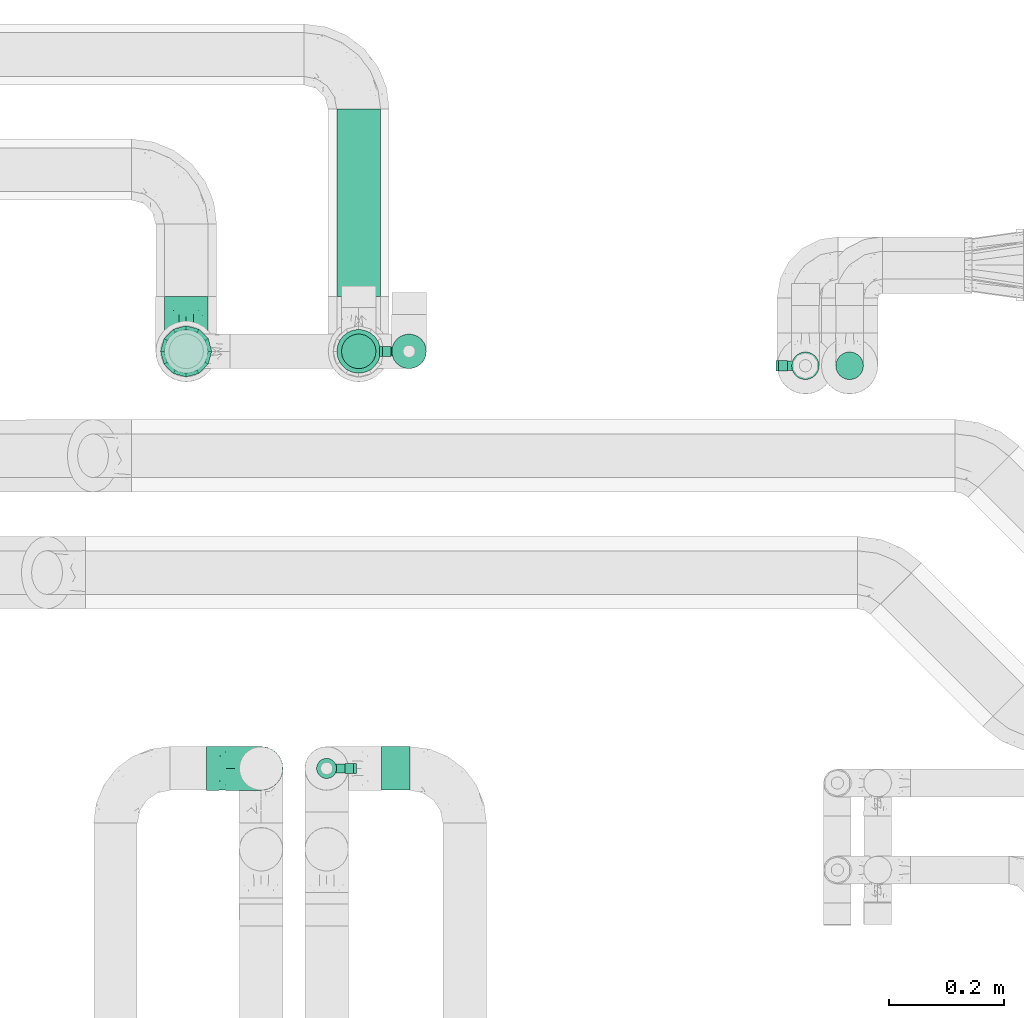
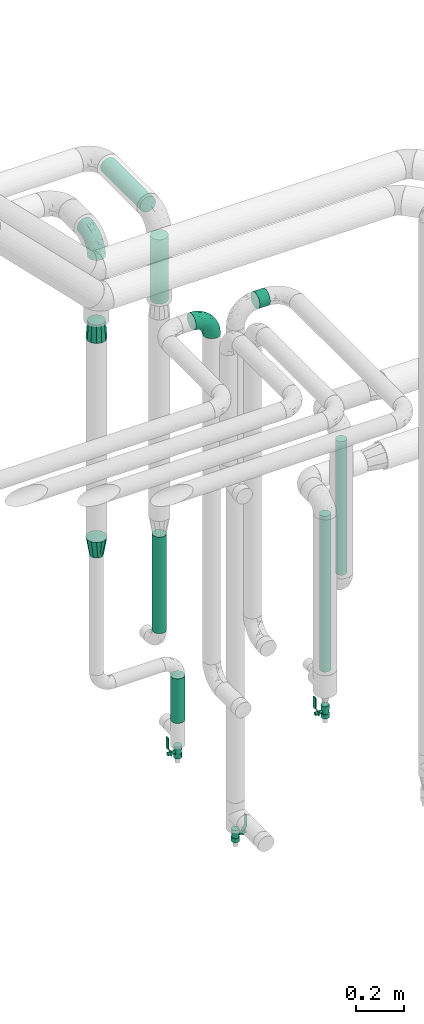
# One storey, part 682 of 827: 7 flow segments, 4 flow fittings, 3 flow controllers.
"""IFC2X3 building model written with IfcOpenShell, lengths in millimetres."""

import ifcopenshell
import ifcopenshell.guid

model = None  # the IFC model being written
_history = None  # IfcOwnerHistory: only IFC2X3 demands one
_inside = {}  # id of a spatial element -> (the spatial element, [elements in it])
_under = {}  # id of a project, library or spatial element -> (it, [spatial elements below it])
_declared = {}  # id of a project -> (the project, [libraries it declares])
_typed = {}  # id of a type object -> (the type object, [elements of that type])
_made_of = {}  # id of a material, layer set ... -> (it, [elements and type objects made of it])


def new_model(schema):
    """Start an empty IFC model of exactly this schema.

    Asked for "IFC4X3", IfcOpenShell would pick the latest addendum, in which some entities
    have other attributes; the version numbers below select the first issue.
    IFC2X3 requires an IfcOwnerHistory on every rooted entity: one is made here for all.
    """
    global model, _history
    if schema == "IFC4X3":
        model = ifcopenshell.file(schema_version=(4, 3, 0, 0))
    else:
        model = ifcopenshell.file(schema=schema)
    _inside.clear()
    _under.clear()
    _declared.clear()
    _typed.clear()
    _made_of.clear()
    _history = None
    if model.schema == "IFC2X3":
        org = make("IfcOrganization", Name="unknown")
        user = make(
            "IfcPersonAndOrganization",
            ThePerson=make("IfcPerson", FamilyName="unknown"),
            TheOrganization=org,
        )
        app = make(
            "IfcApplication",
            ApplicationDeveloper=org,
            Version="unknown",
            ApplicationFullName="unknown",
            ApplicationIdentifier="unknown",
        )
        _history = make(
            "IfcOwnerHistory",
            OwningUser=user,
            OwningApplication=app,
            ChangeAction="ADDED",
            CreationDate=0,
        )
    return model


def make(cls, **values):
    """One entity of the class cls with the attributes given. An attribute that is None is left unset."""
    return model.create_entity(
        cls, **{name: value for name, value in values.items() if value is not None}
    )


def entity(cls, *values):
    """Any entity or typed value of the class cls, its attributes in the order of the schema. None: left unset."""
    e = model.create_entity(cls)
    for i, value in enumerate(values):
        if value is not None:
            e[i] = value
    return e


def rooted(cls, **values):
    """An entity with a GlobalId (a new one), such as an element, a storey or a relation."""
    return make(cls, GlobalId=ifcopenshell.guid.new(), OwnerHistory=_history, **values)


def si_unit(unit_type, name, prefix=None):
    """IfcSIUnit, for example si_unit("LENGTHUNIT", "METRE", prefix="MILLI")."""
    return make("IfcSIUnit", UnitType=unit_type, Prefix=prefix, Name=name)


def converted_unit(unit_type, name, factor, base, dimensions=None, offset=None):
    """IfcConversionBasedUnit, such as the inch: factor (a typed value) times the base unit."""
    return make(
        "IfcConversionBasedUnit"
        if offset is None
        else "IfcConversionBasedUnitWithOffset",
        ConversionOffset=offset,
        Dimensions=None
        if dimensions is None
        else entity("IfcDimensionalExponents", *dimensions),
        UnitType=unit_type,
        Name=name,
        ConversionFactor=make(
            "IfcMeasureWithUnit", ValueComponent=factor, UnitComponent=base
        ),
    )


def derived_unit(unit_type, elements):
    """IfcDerivedUnit: a product of units, each with its exponent."""
    return make(
        "IfcDerivedUnit",
        Elements=[
            make("IfcDerivedUnitElement", Unit=unit, Exponent=power)
            for unit, power in elements
        ],
        UnitType=unit_type,
    )


def assignment(units):
    """IfcUnitAssignment: the units of a project."""
    return None if units is None else make("IfcUnitAssignment", Units=units)


def point(xyz):
    """IfcCartesianPoint."""
    return None if xyz is None else make("IfcCartesianPoint", Coordinates=xyz)


def direction(xyz):
    """IfcDirection."""
    return None if xyz is None else make("IfcDirection", DirectionRatios=xyz)


def frame(location, z_axis=None, x_axis=None):
    """IfcAxis2Placement3D, a coordinate frame: its origin and axes. An axis left out is left unset."""
    return make(
        "IfcAxis2Placement3D",
        Location=point(location),
        Axis=direction(z_axis),
        RefDirection=direction(x_axis),
    )


def frame_2d(location, x_axis=None):
    """IfcAxis2Placement2D, a coordinate frame in the plane: its origin and x axis."""
    return make(
        "IfcAxis2Placement2D", Location=point(location), RefDirection=direction(x_axis)
    )


def origin():
    """The frame at (0, 0, 0) with its axes left unset."""
    return frame((0.0, 0.0, 0.0))


def origin_2d_with_axis():
    """The frame at (0, 0) in the plane with the x axis (1, 0) written out."""
    return frame_2d((0.0, 0.0), x_axis=(1.0, 0.0))


def place(relative_to, where):
    """IfcLocalPlacement: puts the frame where relative to a parent placement (None: the world)."""
    return make(
        "IfcLocalPlacement", PlacementRelTo=relative_to, RelativePlacement=where
    )


def context(
    kind, dimensions, precision=None, world=None, true_north=None, identifier=None
):
    """IfcGeometricRepresentationContext, for example the 3D "Model" context."""
    return make(
        "IfcGeometricRepresentationContext",
        ContextIdentifier=identifier,
        ContextType=kind,
        CoordinateSpaceDimension=dimensions,
        Precision=precision,
        WorldCoordinateSystem=world,
        TrueNorth=true_north,
    )


def subcontext(parent, identifier, kind, view, scale=None):
    """IfcGeometricRepresentationSubContext, for example "Body" below "Model"."""
    return make(
        "IfcGeometricRepresentationSubContext",
        ContextIdentifier=identifier,
        ContextType=kind,
        ParentContext=parent,
        TargetScale=scale,
        TargetView=view,
    )


def project(units=None, contexts=None):
    """IfcProject with its units and contexts."""
    return rooted(
        "IfcProject",
        Name="project",
        RepresentationContexts=contexts,
        UnitsInContext=assignment(units),
    )


def spatial(cls, under=None, at=None, **own):
    """A site, building, storey or space (cls), placed at a placement, below another one or the project."""
    s = rooted(cls, ObjectPlacement=at, **own)
    if under is not None:
        _under.setdefault(under.id(), (under, []))[1].append(s)
    return s


def polyline(points):
    """IfcPolyline through the points."""
    return make("IfcPolyline", Points=[point(p) for p in points])


def profile(cls, at=None, kind="AREA", **sizes):
    """A parametric profile (cls). Its sizes go by their IFC names, for example OverallWidth=200.0."""
    return make(cls, ProfileType=kind, Position=at, **sizes)


def circle(**sizes):
    """IfcCircleProfileDef."""
    return profile("IfcCircleProfileDef", **sizes)


def outline(outer, holes=None, kind="AREA"):
    """IfcArbitraryClosedProfileDef: a profile drawn as a closed curve; with holes, ...WithVoids."""
    if holes is None:
        return make("IfcArbitraryClosedProfileDef", ProfileType=kind, OuterCurve=outer)
    return make(
        "IfcArbitraryProfileDefWithVoids",
        ProfileType=kind,
        OuterCurve=outer,
        InnerCurves=holes,
    )


def extrude(swept, where, along, depth):
    """IfcExtrudedAreaSolid: the profile swept, set in the frame where, extruded along a direction by depth."""
    return make(
        "IfcExtrudedAreaSolid",
        SweptArea=swept,
        Position=where,
        ExtrudedDirection=direction(along),
        Depth=depth,
    )


def faces_of(points, faces, orient=None, outer=None):
    """IfcFace entities. A face is a list of loops; a loop is a list of indices into points, from 0.

    orient and outer hold one flag for each loop. By default every Orientation is true, the
    first loop of a face is its IfcFaceOuterBound and the others are IfcFaceBound.
    """
    made = []
    for i, loops in enumerate(faces):
        bounds = []
        for j, loop in enumerate(loops):
            is_outer = j == 0 if outer is None else outer[i][j]
            bounds.append(
                make(
                    "IfcFaceOuterBound" if is_outer else "IfcFaceBound",
                    Bound=make("IfcPolyLoop", Polygon=[points[k] for k in loop]),
                    Orientation=True if orient is None else orient[i][j],
                )
            )
        made.append(make("IfcFace", Bounds=bounds))
    return made


def faceted_brep(points, faces, orient=None, outer=None, voids=None):
    """IfcFacetedBrep: a solid bounded by flat faces; with voids (closed shells), ...WithVoids."""
    shared = [point(p) for p in points]
    hull = make("IfcClosedShell", CfsFaces=faces_of(shared, faces, orient, outer))
    if voids is None:
        return make("IfcFacetedBrep", Outer=hull)
    return make(
        "IfcFacetedBrepWithVoids",
        Outer=hull,
        Voids=[
            make(cls, CfsFaces=faces_of(shared, fs, o, b)) for cls, fs, o, b in voids
        ],
    )


def shape(context_of_items, identifier, shape_type, items):
    """IfcShapeRepresentation: the items that make up one representation, for example the "Body"."""
    return make(
        "IfcShapeRepresentation",
        ContextOfItems=context_of_items,
        RepresentationIdentifier=identifier,
        RepresentationType=shape_type,
        Items=items,
    )


def source(mapping_origin, context_of_items, identifier, shape_type, items):
    """IfcRepresentationMap: a shape defined once, which mapped items show again and again."""
    return make(
        "IfcRepresentationMap",
        MappingOrigin=mapping_origin,
        MappedRepresentation=shape(context_of_items, identifier, shape_type, items),
    )


def transform(
    local_origin,
    x_axis=None,
    y_axis=None,
    z_axis=None,
    scale=None,
    scale2=None,
    scale3=None,
    uniform=True,
):
    """IfcCartesianTransformationOperator3D, or its non-uniform kind. x_axis, y_axis, z_axis: its Axis1, 2, 3."""
    if uniform:
        return make(
            "IfcCartesianTransformationOperator3D",
            Axis1=direction(x_axis),
            Axis2=direction(y_axis),
            LocalOrigin=point(local_origin),
            Scale=scale,
            Axis3=direction(z_axis),
        )
    return make(
        "IfcCartesianTransformationOperator3DnonUniform",
        Axis1=direction(x_axis),
        Axis2=direction(y_axis),
        LocalOrigin=point(local_origin),
        Scale=scale,
        Axis3=direction(z_axis),
        Scale2=scale2,
        Scale3=scale3,
    )


def mapped(mapping_source, mapping_target):
    """IfcMappedItem: shows the shape of a source again, moved by a transform."""
    return make(
        "IfcMappedItem", MappingSource=mapping_source, MappingTarget=mapping_target
    )


def material(Name=None, Category=None):
    """IfcMaterial."""
    return make("IfcMaterial", Name=Name, Category=Category)


def material_list(materials):
    """IfcMaterialList."""
    return make("IfcMaterialList", Materials=materials)


def made_of(thing, what):
    """Note that an element or type object is made of a material, layer set ...; save() writes the relation."""
    if what is not None:
        _made_of.setdefault(what.id(), (what, []))[1].append(thing)
    return thing


def type_object(cls, material=None, **own):
    """A type object (cls), such as IfcWallType, which elements share."""
    return made_of(rooted(cls, **own), material)


def type_shapes(of_type, sources):
    """Give a type object the sources (RepresentationMaps) that its elements show as mapped items."""
    of_type.RepresentationMaps = sources


def element(
    cls,
    number,
    at=None,
    inside=None,
    cuts=None,
    type_object=None,
    material=None,
    context=None,
    identifier="Body",
    shape_type=None,
    held_by="IfcProductDefinitionShape",
    body=None,
    shapes=None,
    **own,
):
    """One element of the class cls, such as IfcWall. Its Tag is "e" and its number.

    at: its placement. inside: the storey or other place that contains it. cuts: it is an
    opening in that element (IfcRelVoidsElement). A single representation is given by context,
    identifier, shape_type and body (its items); several are given by shapes. held_by: the class
    of the entity that holds the representations. save() writes the other relations.
    """
    e = rooted(cls, Tag="e%d" % number, ObjectPlacement=at, **own)
    if body is not None:
        shapes = [shape(context, identifier, shape_type, body)]
    if shapes is not None:
        e.Representation = make(held_by, Representations=shapes)
    if inside is not None:
        _inside.setdefault(inside.id(), (inside, []))[1].append(e)
    if cuts is not None:
        rooted(
            "IfcRelVoidsElement", RelatingBuildingElement=cuts, RelatedOpeningElement=e
        )
    if type_object is not None:
        _typed.setdefault(type_object.id(), (type_object, []))[1].append(e)
    return made_of(e, material)


def aggregate(whole, parts):
    """IfcRelAggregates: a whole, such as a stair, and the parts it consists of."""
    return rooted("IfcRelAggregates", RelatingObject=whole, RelatedObjects=parts)


def save(model, path):
    """Write the relations noted so far, then the file.

    IfcRelAggregates (storeys below a building ...), IfcRelContainedInSpatialStructure (elements
    in a storey), IfcRelDefinesByType, IfcRelAssociatesMaterial and IfcRelDeclares: one each for
    every whole, place, type object, material and project.
    """
    for whole, parts in _under.values():
        aggregate(whole, parts)
    for where, things in _inside.values():
        rooted(
            "IfcRelContainedInSpatialStructure",
            RelatedElements=things,
            RelatingStructure=where,
        )
    for kind, things in _typed.values():
        rooted("IfcRelDefinesByType", RelatedObjects=things, RelatingType=kind)
    for what, things in _made_of.values():
        rooted("IfcRelAssociatesMaterial", RelatedObjects=things, RelatingMaterial=what)
    for by, libraries in _declared.values():
        rooted("IfcRelDeclares", RelatingContext=by, RelatedDefinitions=libraries)
    model.write(path)


model = new_model("IFC2X3")

# Units and contexts
model_context = context("Model", 3, precision=0.01, world=origin(), true_north=direction((6.12303176911189e-17, 1.0)))
body_context = subcontext(model_context, "Body", "Model", "MODEL_VIEW")
ifc_project = project(units=[si_unit("LENGTHUNIT", "METRE", prefix="MILLI"), si_unit("AREAUNIT", "SQUARE_METRE"), si_unit("VOLUMEUNIT", "CUBIC_METRE"), converted_unit("PLANEANGLEUNIT", "DEGREE", entity("IfcRatioMeasure", 0.0174532925199433), si_unit("PLANEANGLEUNIT", "RADIAN"), dimensions=[0, 0, 0, 0, 0, 0, 0]), si_unit("MASSUNIT", "GRAM", prefix="KILO"), derived_unit("MASSDENSITYUNIT", [(si_unit("MASSUNIT", "GRAM", prefix="KILO"), 1), (si_unit("LENGTHUNIT", "METRE"), -3)]), derived_unit("MOMENTOFINERTIAUNIT", [(si_unit("LENGTHUNIT", "METRE"), 4)]), si_unit("TIMEUNIT", "SECOND"), si_unit("FREQUENCYUNIT", "HERTZ"), si_unit("THERMODYNAMICTEMPERATUREUNIT", "DEGREE_CELSIUS"), derived_unit("THERMALTRANSMITTANCEUNIT", [(si_unit("MASSUNIT", "GRAM", prefix="KILO"), 1), (si_unit("THERMODYNAMICTEMPERATUREUNIT", "KELVIN"), -1), (si_unit("TIMEUNIT", "SECOND"), -3)]), derived_unit("VOLUMETRICFLOWRATEUNIT", [(si_unit("LENGTHUNIT", "METRE"), 3), (si_unit("TIMEUNIT", "SECOND"), -1)]), derived_unit("MASSFLOWRATEUNIT", [(si_unit("MASSUNIT", "GRAM", prefix="KILO"), 1), (si_unit("TIMEUNIT", "SECOND"), -1)]), derived_unit("ROTATIONALFREQUENCYUNIT", [(si_unit("TIMEUNIT", "SECOND"), -1)]), si_unit("ELECTRICCURRENTUNIT", "AMPERE"), si_unit("ELECTRICVOLTAGEUNIT", "VOLT"), si_unit("POWERUNIT", "WATT"), si_unit("FORCEUNIT", "NEWTON", prefix="KILO"), si_unit("ILLUMINANCEUNIT", "LUX"), si_unit("LUMINOUSFLUXUNIT", "LUMEN"), si_unit("LUMINOUSINTENSITYUNIT", "CANDELA"), derived_unit("USERDEFINED", [(si_unit("MASSUNIT", "GRAM", prefix="KILO"), -1), (si_unit("LENGTHUNIT", "METRE"), -2), (si_unit("TIMEUNIT", "SECOND"), 3), (si_unit("LUMINOUSFLUXUNIT", "LUMEN"), 1)]), derived_unit("LINEARVELOCITYUNIT", [(si_unit("LENGTHUNIT", "METRE"), 1), (si_unit("TIMEUNIT", "SECOND"), -1)]), si_unit("PRESSUREUNIT", "PASCAL"), derived_unit("USERDEFINED", [(si_unit("LENGTHUNIT", "METRE"), -2), (si_unit("MASSUNIT", "GRAM", prefix="KILO"), 1), (si_unit("TIMEUNIT", "SECOND"), -2)]), derived_unit("LINEARFORCEUNIT", [(si_unit("MASSUNIT", "GRAM", prefix="KILO"), 1), (si_unit("LENGTHUNIT", "METRE"), 1), (si_unit("TIMEUNIT", "SECOND"), -2), (si_unit("LENGTHUNIT", "METRE"), -1)]), derived_unit("PLANARFORCEUNIT", [(si_unit("MASSUNIT", "GRAM", prefix="KILO"), 1), (si_unit("LENGTHUNIT", "METRE"), 1), (si_unit("TIMEUNIT", "SECOND"), -2), (si_unit("LENGTHUNIT", "METRE"), -2)])], contexts=[model_context])

# Site, building, storey
site_placement = place(None, origin())
site = spatial("IfcSite", under=ifc_project, at=site_placement, CompositionType="ELEMENT")
building_placement = place(site_placement, origin())
building = spatial("IfcBuilding", under=site, at=building_placement, CompositionType="ELEMENT")
storey_placement = place(building_placement, frame((0.0, 0.0, 28200.0)))
storey = spatial("IfcBuildingStorey", under=building, at=storey_placement, Name="08", CompositionType="ELEMENT", Elevation=28200.0)

# Flow segments
pipe_segment_type_1 = type_object("IfcPipeSegmentType", PredefinedType="NOTDEFINED")
flow_segment_1_placement = place(storey_placement, frame((46768.22, 19086.22, 2960.4)))
element("IfcFlowSegment", 1, at=flow_segment_1_placement, inside=storey, type_object=pipe_segment_type_1, context=body_context, shape_type="SweptSolid", body=[
    extrude(circle(Radius=38.0, at=origin_2d_with_axis()), frame((39.6, 0.0, 39.6), z_axis=(0.0, 1.0, 0.0), x_axis=(-1.0, 0.0, 0.0)), (0.0, 0.0, 1.0), 326.0116),
])
flow_segment_2_placement = place(storey_placement, frame((46768.22, 18951.63, 2580.0)))
element("IfcFlowSegment", 2, at=flow_segment_2_placement, inside=storey, type_object=pipe_segment_type_1, context=body_context, shape_type="SweptSolid", body=[
    extrude(circle(Radius=38.0, at=origin_2d_with_axis()), frame((39.6, 39.6, 0.0)), (0.0, 0.0, 1.0), 325.000000000017),
])
pipe_segment_type_2 = type_object("IfcPipeSegmentType", PredefinedType="NOTDEFINED")
flow_segment_3_placement = place(storey_placement, frame((46847.07, 18226.89, 2960.65)))
element("IfcFlowSegment", 3, at=flow_segment_3_placement, inside=storey, type_object=pipe_segment_type_2, context=body_context, shape_type="SweptSolid", body=[
    extrude(circle(Radius=37.75, at=origin_2d_with_axis()), frame((0.0, 39.35, 39.35), z_axis=(1.0, 0.0, 0.0), x_axis=(0.0, 1.0, 0.0)), (0.0, 0.0, 1.0), 50.000000000006),
])
flow_segment_4_placement = place(storey_placement, frame((47558.7, 18940.63, 457.0)))
element("IfcFlowSegment", 4, at=flow_segment_4_placement, inside=storey, type_object=pipe_segment_type_2, context=body_context, shape_type="SweptSolid", body=[
    extrude(circle(Radius=24.0, at=origin_2d_with_axis()), frame((25.6, 25.6, 0.0)), (0.0, 0.0, 1.0), 785.999999709128),
])
flow_segment_5_placement = place(storey_placement, frame((47635.58, 18940.63, 918.88)))
element("IfcFlowSegment", 5, at=flow_segment_5_placement, inside=storey, type_object=pipe_segment_type_2, context=body_context, shape_type="SweptSolid", body=[
    extrude(circle(Radius=24.0, at=origin_2d_with_axis()), frame((25.6, 25.6, 0.0), z_axis=(0.0, 0.0, 1.0), x_axis=(-1.0, 0.0, 0.0)), (0.0, 0.0, 1.0), 674.12499999997),
])
flow_segment_6_placement = place(storey_placement, frame((46776.22, 18959.63, 912.38)))
element("IfcFlowSegment", 6, at=flow_segment_6_placement, inside=storey, type_object=pipe_segment_type_2, context=body_context, shape_type="SweptSolid", body=[
    extrude(circle(Radius=30.0, at=origin_2d_with_axis()), frame((31.6, 31.6, 0.0), z_axis=(0.0, 0.0, 1.0), x_axis=(-1.0, 0.0, 0.0)), (0.0, 0.0, 1.0), 486.500000000002),
])
flow_segment_7_placement = place(storey_placement, frame((46863.72, 18959.63, 429.0)))
element("IfcFlowSegment", 7, at=flow_segment_7_placement, inside=storey, type_object=pipe_segment_type_2, context=body_context, shape_type="SweptSolid", body=[
    extrude(circle(Radius=30.0, at=origin_2d_with_axis()), frame((31.6, 31.6, 0.0)), (0.0, 0.0, 1.0), 224.999999999888),
])

# Flow controllers
ifc_material = material()
ifc_material_list = material_list([ifc_material, ifc_material, ifc_material, ifc_material, ifc_material])
valve_type = type_object("IfcValveType", PredefinedType="NOTDEFINED", material=ifc_material_list)
shared_shape_1 = source(origin(), body_context, "Body", "SweptSolid", [
    extrude(circle(Radius=17.5, at=origin_2d_with_axis()), frame((-30.5, 0.0, 0.0), z_axis=(1.0, 0.0, 0.0), x_axis=(0.0, 1.0, 0.0)), (0.0, 0.0, 1.0), 20.3333333333333),
    extrude(circle(Radius=16.0, at=origin_2d_with_axis()), frame((-10.17, 0.0, 0.0), z_axis=(1.0, 0.0, 0.0), x_axis=(0.0, 1.0, 0.0)), (0.0, 0.0, 1.0), 20.3333333333333),
    extrude(circle(Radius=17.5, at=origin_2d_with_axis()), frame((10.17, 0.0, 0.0), z_axis=(1.0, 0.0, 0.0), x_axis=(0.0, 1.0, 0.0)), (0.0, 0.0, 1.0), 20.3333333333333),
    extrude(outline(polyline([(-38.75, -5.0), (-38.75, -10.0), (-17.92, -10.0), (2.08, 5.0), (56.25, 5.0), (56.25, 10.0), (0.42, 10.0), (-19.58, -5.0), (-38.75, -5.0)])), frame((28.75, -8.75, 41.5), z_axis=(0.0, -1.0, 0.0), x_axis=(1.0, 0.0, 0.0)), (0.0, 0.0, -1.0), 17.5),
    extrude(circle(Radius=8.0, at=origin_2d_with_axis()), origin(), (0.0, 0.0, 1.0), 49.0),
])
type_shapes(valve_type, [shared_shape_1])
for number, where, z_axis, x_axis in (
    (8, (47584.3, 18966.22, 247.5), (-1.0, 0.0, 0.0), (0.0, 0.0, 1.0)),
    (9, (46895.32, 18991.22, 270.5), (-1.0, 0.0, 0.0), (0.0, 0.0, 1.0)),
    (10, (46752.07, 18266.24, 338.5), (1.0, 0.0, 0.0), (0.0, 0.0, 1.0)),
):
    element("IfcFlowController", number, at=place(storey_placement, frame(where, z_axis=z_axis, x_axis=x_axis)), inside=storey, type_object=valve_type, material=ifc_material, context=body_context, shape_type="MappedRepresentation", body=[
        mapped(shared_shape_1, transform((0.0, 0.0, 0.0), scale=1.0)),
    ])

# Flow fittings
pipe_fitting_type_1 = type_object("IfcPipeFittingType", Name="ADSK_1", PredefinedType="NOTDEFINED", material=ifc_material)
shared_shape_2 = source(origin(), body_context, "Body", "Brep", [
    faceted_brep([(-95.0, 19.02, -32.95), (-95.0, 9.85, -36.75), (-95.0, 0.0, -38.05), (-95.0, -9.85, -36.75), (-95.0, -19.03, -32.95), (-95.0, -26.91, -26.91), (-95.0, -32.95, -19.03), (-95.0, -36.75, -9.85), (-95.0, -38.05, 0.0), (-95.0, -36.75, 9.85), (-95.0, -32.95, 19.02), (-95.0, -26.91, 26.91), (-95.0, -19.03, 32.95), (-95.0, -9.85, 36.75), (-95.0, 0.0, 38.05), (-95.0, 9.85, 36.75), (-95.0, 19.02, 32.95), (-95.0, 26.91, 26.91), (-95.0, 32.95, 19.02), (-95.0, 36.75, 9.85), (-95.0, 38.05, 0.0), (-95.0, 36.75, -9.85), (-95.0, 32.95, -19.03), (-95.0, 26.91, -26.91), (0.0, 95.0, -38.05), (-9.85, 95.0, -36.75), (-19.02, 95.0, -32.95), (-26.91, 95.0, -26.91), (-32.95, 95.0, -19.03), (-36.75, 95.0, -9.85), (-38.05, 95.0, 0.0), (-36.75, 95.0, 9.85), (-32.95, 95.0, 19.02), (-26.91, 95.0, 26.91), (-19.02, 95.0, 32.95), (-9.85, 95.0, 36.75), (0.0, 95.0, 38.05), (9.85, 95.0, 36.75), (19.03, 95.0, 32.95), (26.91, 95.0, 26.91), (32.95, 95.0, 19.02), (36.75, 95.0, 9.85), (38.05, 95.0, 0.0), (36.75, 95.0, -9.85), (32.95, 95.0, -19.03), (26.91, 95.0, -26.91), (19.03, 95.0, -32.95), (9.85, 95.0, -36.75), (-7.99, -4.96, 6.3), (-0.92, 0.92, 0.0), (4.62, 8.1, 8.01), (-76.19, -35.57, 0.0), (-64.32, -32.32, 12.43), (20.51, 62.45, 28.68), (-60.56, -33.52, 0.0), (-70.4, -13.47, 34.42), (-39.61, -5.88, 32.32), (-49.6, 2.07, 37.1), (-70.34, -28.81, 21.71), (14.64, 40.81, 26.5), (5.88, 39.61, 32.32), (3.59, 20.77, 25.31), (-40.45, 68.06, 16.75), (-62.45, -20.51, 28.68), (-44.52, -26.87, 0.0), (-28.47, -20.22, 0.0), (-26.43, -17.83, 8.75), (-76.1, 39.63, 10.76), (-72.74, 37.58, 18.19), (-60.35, 46.18, 14.61), (-13.4, 13.4, 32.12), (-20.77, -3.59, 25.31), (-14.66, 81.47, 35.56), (-6.22, 71.26, 37.92), (-57.5, 42.48, 22.79), (-15.0, 34.74, 37.7), (-27.1, 12.08, 36.05), (-9.2, 28.81, 35.63), (-79.98, 23.7, 30.95), (-73.68, -4.3, 37.48), (-30.74, 21.67, 37.97), (-62.36, 47.59, 6.79), (-72.71, 32.83, 24.69), (-67.42, 7.02, 37.95), (-32.13, 75.27, 24.51), (-43.46, 51.47, 26.26), (-24.98, 73.15, 31.29), (20.59, 41.28, 19.85), (7.79, 16.09, 15.86), (-73.21, 42.39, 0.0), (-54.73, 54.73, 0.0), (-73.44, 15.79, 35.79), (-5.94, 4.32, 20.43), (28.81, 70.34, 21.71), (32.32, 64.32, 12.43), (-53.59, 26.2, 35.09), (-52.02, 19.31, 37.21), (21.38, 33.53, 10.34), (26.87, 44.52, 0.0), (-48.28, 12.14, 38.05), (4.3, 73.68, 37.48), (-44.08, -25.52, 12.79), (-41.28, -20.59, 19.85), (35.57, 76.19, 0.0), (-47.26, 54.3, 20.18), (-47.4, 61.99, 8.58), (-42.39, 73.21, 0.0), (-39.67, 78.86, 7.21), (-45.69, 36.84, 33.11), (-32.83, 50.13, 33.35), (13.47, 70.4, 34.42), (-18.25, 63.73, 36.07), (-40.63, -13.75, 27.22), (-16.63, 46.37, 37.95), (-53.47, 38.79, 28.59), (-26.07, 48.54, 36.15), (-34.51, 34.51, 36.86), (-2.07, 49.6, 37.1), (-22.79, -10.49, 19.23), (-61.73, 28.67, 31.87), (9.65, 14.7, 0.0), (20.22, 28.47, 0.0), (33.52, 60.56, 0.0), (-11.42, -5.44, 13.25), (-14.7, -9.65, 0.0), (-81.47, 14.66, -35.56), (-62.45, -20.51, -28.68), (-71.26, 6.22, -37.92), (-75.27, 32.13, -24.51), (-73.15, 24.98, -31.29), (13.47, 70.4, -34.42), (5.88, 39.61, -32.32), (-2.07, 49.6, -37.1), (-78.86, 39.67, -7.21), (-70.4, -13.47, -34.42), (-39.61, -5.88, -32.32), (-61.99, 47.4, -8.58), (32.32, 64.32, -12.43), (28.81, 70.34, -21.71), (-63.73, 18.25, -36.07), (-50.13, 32.83, -33.35), (4.3, 73.68, -37.48), (-7.02, 67.42, -37.95), (-39.63, 76.1, -10.76), (-46.18, 60.35, -14.61), (-47.59, 62.36, -6.79), (-64.32, -32.32, -12.43), (-26.2, 53.59, -35.09), (-15.79, 73.44, -35.79), (-19.31, 52.02, -37.21), (-37.58, 72.74, -18.19), (-70.34, -28.81, -21.71), (-42.48, 57.5, -22.79), (-38.79, 53.47, -28.59), (-51.47, 43.46, -26.26), (-32.83, 72.71, -24.69), (-46.37, 16.63, -37.95), (-73.68, -4.3, -37.48), (-41.28, -20.59, -19.85), (-44.08, -25.52, -12.79), (13.75, 40.63, -27.22), (20.51, 62.45, -28.68), (-68.06, 40.45, -16.75), (-54.3, 47.26, -20.18), (-12.14, 48.28, -38.05), (-21.67, 30.74, -37.97), (-36.84, 45.69, -33.11), (-11.42, -5.44, -13.25), (7.79, 16.09, -15.86), (4.62, 8.1, -8.01), (-23.7, 79.98, -30.95), (-26.43, -17.83, -8.75), (-7.99, -4.96, -6.3), (-40.81, -14.64, -26.5), (-20.77, -3.59, -25.31), (-34.74, 15.0, -37.7), (-12.08, 27.1, -36.05), (-28.81, 9.2, -35.63), (-22.79, -10.49, -19.23), (21.38, 33.53, -10.34), (20.59, 41.28, -19.85), (-48.54, 26.07, -36.15), (-49.6, 2.07, -37.1), (-13.4, 13.4, -32.12), (3.59, 20.77, -25.31), (-28.67, 61.73, -31.87), (-34.51, 34.51, -36.86), (-5.94, 4.32, -20.43)], [[[0, 1, 2, 3, 4, 5, 6, 7, 8, 9, 10, 11, 12, 13, 14, 15, 16, 17, 18, 19, 20, 21, 22, 23]], [[24, 25, 26, 27, 28, 29, 30, 31, 32, 33, 34, 35, 36, 37, 38, 39, 40, 41, 42, 43, 44, 45, 46, 47]], [[48, 49, 50]], [[51, 52, 9]], [[53, 39, 38]], [[9, 52, 10]], [[54, 52, 51]], [[55, 56, 57]], [[11, 10, 58]], [[59, 60, 61]], [[32, 31, 62]], [[63, 12, 11]], [[63, 55, 12]], [[64, 65, 66]], [[67, 68, 69]], [[70, 56, 71]], [[35, 72, 73]], [[69, 68, 74]], [[75, 76, 77]], [[16, 78, 17]], [[13, 79, 14]], [[76, 75, 80]], [[67, 69, 81]], [[18, 17, 82]], [[14, 79, 83]], [[20, 19, 67]], [[84, 85, 86]], [[87, 61, 88]], [[89, 81, 90]], [[18, 82, 68]], [[15, 91, 16]], [[14, 83, 15]], [[71, 92, 61]], [[17, 78, 82]], [[93, 87, 94]], [[95, 91, 96]], [[97, 98, 94]], [[86, 72, 34]], [[96, 99, 80]], [[37, 36, 100]], [[40, 39, 93]], [[40, 94, 41]], [[64, 66, 101]], [[93, 94, 40]], [[58, 102, 63]], [[94, 103, 41]], [[94, 87, 97]], [[104, 69, 74]], [[34, 33, 86]], [[105, 69, 104]], [[52, 58, 10]], [[106, 107, 30]], [[108, 109, 85]], [[105, 106, 90]], [[53, 110, 60]], [[86, 111, 72]], [[86, 109, 111]], [[33, 84, 86]], [[12, 55, 13]], [[112, 56, 63]], [[110, 38, 37]], [[34, 72, 35]], [[36, 35, 73]], [[111, 113, 73]], [[105, 107, 106]], [[110, 53, 38]], [[74, 114, 85]], [[91, 15, 83]], [[105, 90, 81]], [[107, 62, 31]], [[33, 32, 84]], [[115, 109, 116]], [[111, 115, 113]], [[100, 73, 117]], [[56, 55, 63]], [[79, 55, 57]], [[102, 118, 112]], [[56, 70, 76]], [[100, 110, 37]], [[117, 77, 60]], [[117, 60, 110]], [[60, 70, 61]], [[58, 52, 101]], [[63, 11, 58]], [[39, 53, 93]], [[87, 93, 53]], [[96, 91, 83]], [[78, 91, 119]], [[32, 62, 84]], [[84, 62, 104]], [[86, 85, 109]], [[85, 114, 108]], [[80, 113, 116]], [[117, 73, 113]], [[80, 116, 96]], [[80, 57, 76]], [[71, 112, 118]], [[61, 87, 59]], [[62, 107, 105]], [[97, 120, 121]], [[70, 71, 61]], [[71, 118, 92]], [[73, 100, 36]], [[110, 100, 117]], [[55, 79, 13]], [[83, 79, 57]], [[96, 83, 99]], [[116, 108, 95]], [[50, 97, 88]], [[97, 87, 88]], [[50, 49, 120]], [[122, 94, 98]], [[89, 20, 67]], [[105, 81, 69]], [[89, 67, 81]], [[68, 19, 18]], [[68, 67, 19]], [[74, 68, 82]], [[114, 82, 119]], [[74, 85, 104]], [[82, 114, 74]], [[114, 119, 108]], [[95, 108, 119]], [[116, 109, 108]], [[123, 48, 50]], [[97, 50, 120]], [[123, 50, 88]], [[91, 95, 119]], [[116, 95, 96]], [[84, 104, 85]], [[104, 62, 105]], [[83, 57, 99]], [[57, 80, 99]], [[66, 48, 123]], [[66, 124, 48]], [[118, 66, 123]], [[124, 66, 65]], [[66, 118, 101]], [[54, 64, 52]], [[124, 49, 48]], [[30, 107, 31]], [[91, 78, 16]], [[82, 78, 119]], [[56, 76, 57]], [[77, 76, 70]], [[60, 77, 70]], [[77, 117, 75]], [[117, 113, 75]], [[113, 80, 75]], [[9, 8, 51]], [[103, 94, 122]], [[103, 42, 41]], [[73, 72, 111]], [[113, 115, 116]], [[111, 109, 115]], [[102, 112, 63]], [[71, 56, 112]], [[118, 102, 101]], [[92, 123, 88]], [[123, 92, 118]], [[61, 92, 88]], [[87, 53, 59]], [[60, 59, 53]], [[97, 121, 98]], [[58, 101, 102]], [[64, 101, 52]], [[125, 1, 0]], [[126, 5, 4]], [[2, 1, 127]], [[1, 125, 127]], [[128, 129, 23]], [[130, 131, 132]], [[89, 133, 20]], [[126, 134, 135]], [[136, 89, 90]], [[137, 138, 44]], [[139, 129, 140]], [[24, 141, 142]], [[143, 144, 145]], [[125, 129, 139]], [[6, 146, 7]], [[147, 148, 149]], [[146, 51, 7]], [[143, 150, 144]], [[146, 6, 151]], [[152, 153, 154]], [[126, 4, 134]], [[0, 23, 129]], [[28, 155, 150]], [[43, 42, 103]], [[54, 146, 64]], [[139, 156, 127]], [[157, 3, 2]], [[151, 158, 159]], [[160, 131, 161]], [[22, 21, 162]], [[136, 144, 163]], [[149, 164, 165]], [[24, 142, 25]], [[166, 140, 154]], [[154, 129, 128]], [[143, 30, 29]], [[167, 168, 169]], [[155, 28, 27]], [[26, 170, 27]], [[171, 167, 172]], [[26, 25, 148]], [[27, 170, 155]], [[173, 135, 174]], [[144, 150, 152]], [[175, 176, 177]], [[24, 47, 141]], [[45, 161, 46]], [[148, 25, 142]], [[176, 175, 165]], [[64, 159, 171]], [[138, 45, 44]], [[130, 46, 161]], [[137, 44, 43]], [[178, 159, 158]], [[137, 103, 122]], [[163, 144, 152]], [[136, 133, 89]], [[103, 137, 43]], [[6, 5, 151]], [[178, 158, 173]], [[134, 4, 3]], [[178, 173, 174]], [[137, 98, 179]], [[145, 90, 106]], [[138, 180, 161]], [[46, 130, 47]], [[136, 90, 145]], [[133, 162, 21]], [[23, 22, 128]], [[139, 140, 181]], [[139, 181, 156]], [[157, 127, 182]], [[157, 134, 3]], [[182, 177, 135]], [[182, 135, 134]], [[135, 183, 174]], [[131, 130, 161]], [[141, 130, 132]], [[160, 180, 184]], [[131, 183, 176]], [[5, 126, 151]], [[158, 151, 126]], [[180, 138, 137]], [[161, 45, 138]], [[149, 148, 142]], [[170, 148, 185]], [[22, 162, 128]], [[128, 162, 163]], [[129, 154, 140]], [[154, 153, 166]], [[165, 156, 186]], [[182, 127, 156]], [[165, 186, 149]], [[165, 132, 176]], [[131, 184, 183]], [[187, 167, 178]], [[184, 168, 187]], [[167, 169, 172]], [[184, 180, 168]], [[174, 183, 184]], [[127, 157, 2]], [[134, 157, 182]], [[130, 141, 47]], [[142, 141, 132]], [[149, 142, 164]], [[186, 166, 147]], [[180, 179, 168]], [[169, 179, 120]], [[137, 179, 180]], [[179, 121, 120]], [[106, 30, 143]], [[136, 145, 144]], [[106, 143, 145]], [[150, 29, 28]], [[150, 143, 29]], [[152, 150, 155]], [[153, 155, 185]], [[152, 154, 163]], [[155, 153, 152]], [[153, 185, 166]], [[147, 166, 185]], [[186, 140, 166]], [[169, 120, 49]], [[169, 49, 172]], [[179, 169, 168]], [[148, 147, 185]], [[186, 147, 149]], [[128, 163, 154]], [[163, 162, 136]], [[142, 132, 164]], [[132, 165, 164]], [[171, 124, 65]], [[124, 171, 172]], [[64, 146, 159]], [[171, 159, 178]], [[171, 65, 64]], [[172, 49, 124]], [[162, 133, 136]], [[20, 133, 21]], [[148, 170, 26]], [[155, 170, 185]], [[131, 176, 132]], [[177, 176, 183]], [[135, 177, 183]], [[177, 182, 175]], [[182, 156, 175]], [[156, 165, 175]], [[51, 146, 54]], [[51, 8, 7]], [[129, 125, 0]], [[127, 125, 139]], [[140, 186, 181]], [[156, 181, 186]], [[158, 126, 173]], [[135, 173, 126]], [[187, 178, 174]], [[171, 178, 167]], [[184, 187, 174]], [[167, 187, 168]], [[180, 160, 161]], [[184, 131, 160]], [[98, 137, 122]], [[98, 121, 179]], [[151, 159, 146]]]),
])
type_shapes(pipe_fitting_type_1, [shared_shape_2])
for number, where, z_axis, x_axis, name in (
    (11, (46507.82, 18991.22, 3000.0), (1.0, 0.0, 0.0), (0.0, -1.0, 0.0), "ADSK_1"),
    (12, (46638.03, 18266.24, 3000.0), (0.0, -1.0, 0.0), (0.0, 0.0, 1.0), "ADSK_1"),
):
    element("IfcFlowFitting", number, at=place(storey_placement, frame(where, z_axis=z_axis, x_axis=x_axis)), inside=storey, type_object=pipe_fitting_type_1, material=ifc_material, Name=name, ObjectType="ADSK_1", context=body_context, shape_type="MappedRepresentation", body=[
        mapped(shared_shape_2, transform((0.0, 0.0, 0.0), scale=1.0)),
    ])
pipe_fitting_type_2 = type_object("IfcPipeFittingType", Name="ADSK_1", PredefinedType="NOTDEFINED", material=ifc_material)
shared_shape_3 = source(origin(), body_context, "Body", "Brep", [
    faceted_brep([(89.0, -44.45, 0.0), (89.0, -42.1, -8.76), (89.0, -38.49, -22.22), (89.0, -30.36, -30.36), (89.0, -22.23, -38.49), (89.0, -11.11, -41.47), (89.0, 0.0, -44.45), (89.0, 11.11, -41.47), (89.0, 22.22, -38.49), (89.0, 30.36, -30.36), (89.0, 38.49, -22.22), (89.0, 42.1, -8.76), (89.0, 44.45, 0.0), (89.0, 42.1, 8.76), (89.0, 38.49, 22.23), (89.0, 30.36, 30.36), (89.0, 22.22, 38.49), (89.0, 11.11, 41.47), (89.0, 0.0, 44.45), (89.0, -11.11, 41.47), (89.0, -22.23, 38.49), (89.0, -30.36, 30.36), (89.0, -38.49, 22.23), (89.0, -42.1, 8.76), (0.0, 30.15, 0.0), (0.0, 27.27, -8.86), (0.0, 24.39, -17.72), (0.0, 16.85, -23.2), (0.0, 9.32, -28.67), (0.0, 0.0, -28.67), (0.0, -9.32, -28.67), (0.0, -16.85, -23.2), (0.0, -24.39, -17.72), (0.0, -27.27, -8.86), (0.0, -30.15, 0.0), (0.0, -27.27, 8.86), (0.0, -24.39, 17.72), (0.0, -16.85, 23.2), (0.0, -9.32, 28.67), (0.0, 0.0, 28.67), (0.0, 9.32, 28.67), (0.0, 16.85, 23.2), (0.0, 24.39, 17.72), (0.0, 27.27, 8.86)], [[[0, 1, 2, 3, 4, 5, 6, 7, 8, 9, 10, 11, 12, 13, 14, 15, 16, 17, 18, 19, 20, 21, 22, 23]], [[24, 25, 26, 27, 28, 29, 30, 31, 32, 33, 34, 35, 36, 37, 38, 39, 40, 41, 42, 43]], [[2, 33, 32]], [[28, 7, 29]], [[29, 5, 30]], [[24, 12, 11]], [[3, 32, 31]], [[34, 1, 0]], [[1, 34, 33]], [[8, 28, 27]], [[2, 1, 33]], [[31, 4, 3]], [[2, 32, 3]], [[11, 25, 24]], [[26, 10, 9]], [[10, 25, 11]], [[28, 8, 7]], [[27, 26, 9]], [[26, 25, 10]], [[31, 30, 4]], [[8, 27, 9]], [[29, 7, 6]], [[5, 29, 6]], [[5, 4, 30]], [[14, 43, 42]], [[38, 19, 39]], [[39, 17, 40]], [[34, 0, 23]], [[15, 42, 41]], [[24, 13, 12]], [[13, 24, 43]], [[20, 38, 37]], [[14, 13, 43]], [[41, 16, 15]], [[14, 42, 15]], [[23, 35, 34]], [[36, 22, 21]], [[22, 35, 23]], [[38, 20, 19]], [[37, 36, 21]], [[36, 35, 22]], [[41, 40, 16]], [[20, 37, 21]], [[39, 19, 18]], [[17, 39, 18]], [[17, 16, 40]]]),
])
type_shapes(pipe_fitting_type_2, [shared_shape_3])
flow_fitting_1_placement = place(storey_placement, frame((46507.82, 18991.22, 1398.88), z_axis=(0.0, 1.0, 0.0), x_axis=(0.0, 0.0, 1.0)))
element("IfcFlowFitting", 13, at=flow_fitting_1_placement, inside=storey, type_object=pipe_fitting_type_2, material=ifc_material, Name="ADSK_1", ObjectType="ADSK_1", context=body_context, shape_type="MappedRepresentation", body=[
    mapped(shared_shape_3, transform((0.0, 0.0, 0.0), scale=1.0)),
])
pipe_fitting_type_3 = type_object("IfcPipeFittingType", Name="ADSK_1", PredefinedType="NOTDEFINED", material=ifc_material)
shared_shape_4 = source(origin(), body_context, "Body", "Brep", [
    faceted_brep([(89.0, 38.05, 0.0), (89.0, 35.5, 9.51), (89.0, 32.95, 19.03), (89.0, 25.99, 25.99), (89.0, 19.02, 32.95), (89.0, 9.51, 35.5), (89.0, 0.0, 38.05), (89.0, -9.51, 35.5), (89.0, -19.03, 32.95), (89.0, -25.99, 25.99), (89.0, -32.95, 19.03), (89.0, -35.5, 9.51), (89.0, -38.05, 0.0), (89.0, -35.5, -9.51), (89.0, -32.95, -19.02), (89.0, -25.99, -25.99), (89.0, -19.03, -32.95), (89.0, -9.51, -35.5), (89.0, 0.0, -38.05), (89.0, 9.51, -35.5), (89.0, 19.02, -32.95), (89.0, 25.99, -25.99), (89.0, 32.95, -19.03), (89.0, 35.5, -9.51), (0.0, -38.49, 22.22), (0.0, -30.36, 30.36), (0.0, -22.22, 38.49), (0.0, -11.11, 41.47), (0.0, 0.0, 44.45), (0.0, 11.11, 41.47), (0.0, 22.23, 38.49), (0.0, 30.36, 30.36), (0.0, 38.49, 22.22), (0.0, 41.96, 9.31), (0.0, 44.45, 0.0), (0.0, 41.47, -11.11), (0.0, 38.49, -22.23), (0.0, 30.36, -30.36), (0.0, 22.23, -38.49), (0.0, 11.11, -41.47), (0.0, 0.0, -44.45), (0.0, -11.11, -41.47), (0.0, -22.23, -38.49), (0.0, -30.36, -30.36), (0.0, -38.49, -22.23), (0.0, -41.96, -9.31), (0.0, -44.45, 0.0), (0.0, -41.47, 11.11)], [[[0, 1, 2, 3, 4, 5, 6, 7, 8, 9, 10, 11, 12, 13, 14, 15, 16, 17, 18, 19, 20, 21, 22, 23]], [[24, 25, 26, 27, 28, 29, 30, 31, 32, 33, 34, 35, 36, 37, 38, 39, 40, 41, 42, 43, 44, 45, 46, 47]], [[23, 22, 36, 35, 34, 0]], [[39, 38, 20, 19, 18, 40]], [[38, 37, 36, 22, 21, 20]], [[43, 42, 16, 15, 14, 44]], [[41, 40, 18, 17, 16, 42]], [[12, 46, 45, 44, 14, 13]], [[11, 10, 24, 47, 46, 12]], [[27, 26, 8, 7, 6, 28]], [[26, 25, 24, 10, 9, 8]], [[31, 30, 4, 3, 2, 32]], [[29, 28, 6, 5, 4, 30]], [[0, 34, 33, 32, 2, 1]]]),
])
type_shapes(pipe_fitting_type_3, [shared_shape_4])
flow_fitting_2_placement = place(storey_placement, frame((46507.82, 18991.22, 2491.0), z_axis=(0.0, 1.0, 0.0), x_axis=(0.0, 0.0, 1.0)))
element("IfcFlowFitting", 14, at=flow_fitting_2_placement, inside=storey, type_object=pipe_fitting_type_3, material=ifc_material, Name="ADSK_1", ObjectType="ADSK_1", context=body_context, shape_type="MappedRepresentation", body=[
    mapped(shared_shape_4, transform((0.0, 0.0, 0.0), scale=1.0)),
])

save(model, "model.ifc")
